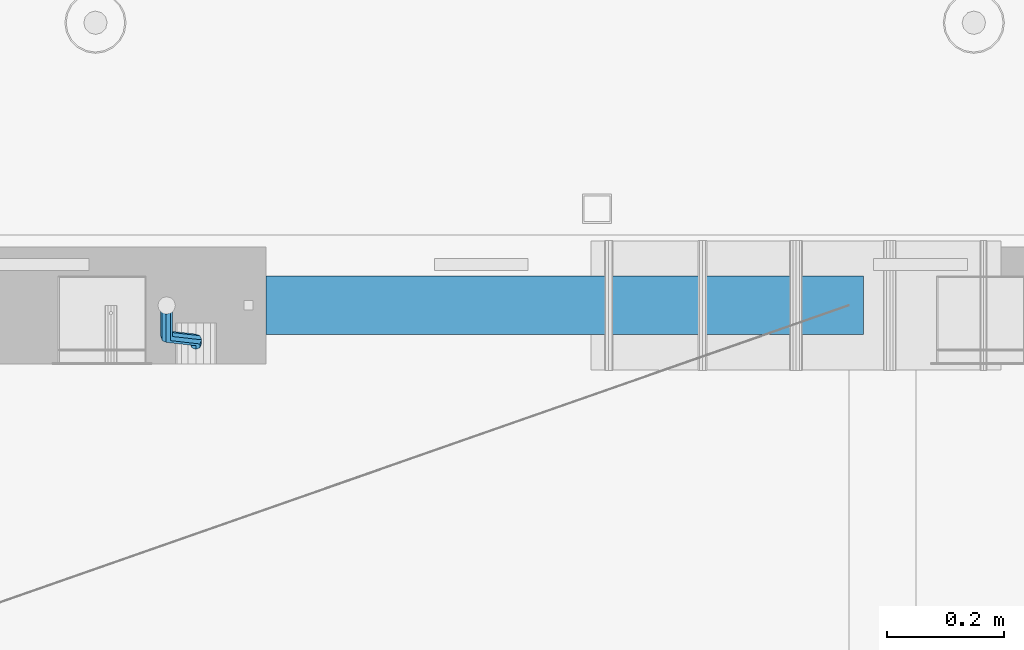
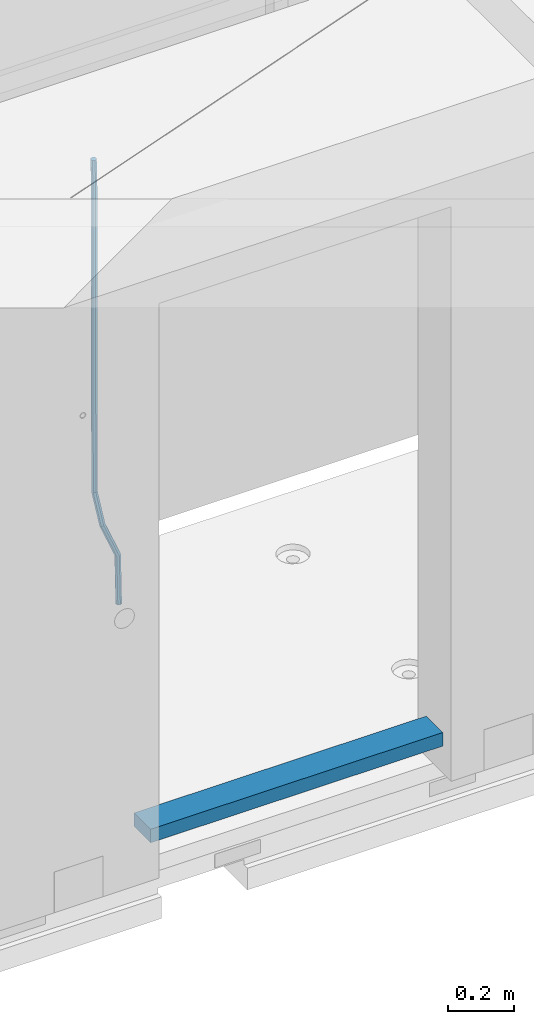
# One storey, part 111 of 352: 2 beams, 1 element without a shape of its own.
"""IFC2X3 building model written with IfcOpenShell, lengths in millimetres."""

from ifc_helpers import new_model, si_unit, frame, origin_with_axes, place, context, subcontext, project, spatial, faceted_brep, material, type_object, element, aggregate, save


model = new_model("IFC2X3")

# Units and contexts
model_context = context("Model", 3, precision=1e-05, world=origin_with_axes())
body_context = subcontext(model_context, "Body", "Model", "MODEL_VIEW")
ifc_project = project(units=[si_unit("LENGTHUNIT", "METRE", prefix="MILLI"), si_unit("AREAUNIT", "SQUARE_METRE"), si_unit("VOLUMEUNIT", "CUBIC_METRE"), si_unit("MASSUNIT", "GRAM", prefix="KILO"), si_unit("TIMEUNIT", "SECOND"), si_unit("PLANEANGLEUNIT", "RADIAN"), si_unit("SOLIDANGLEUNIT", "STERADIAN"), si_unit("THERMODYNAMICTEMPERATUREUNIT", "DEGREE_CELSIUS"), si_unit("LUMINOUSINTENSITYUNIT", "LUMEN")], contexts=[model_context])

# Site, building, storey
site_placement = place(None, origin_with_axes())
site = spatial("IfcSite", under=ifc_project, at=site_placement, CompositionType="ELEMENT")
building_placement = place(site_placement, origin_with_axes())
building = spatial("IfcBuilding", under=site, at=building_placement, CompositionType="ELEMENT")
storey_placement = place(building_placement, origin_with_axes())
storey = spatial("IfcBuildingStorey", under=building, at=storey_placement, Name="6", CompositionType="ELEMENT", Elevation=0.0)

# Assembly, beams
assembly_placement = place(storey_placement, origin_with_axes())
assembly = element("IfcElementAssembly", 1, at=assembly_placement, inside=storey, AssemblyPlace="NOTDEFINED", PredefinedType="REINFORCEMENT_UNIT")
ifc_material_1 = material()
beam_type_1 = type_object("IfcBeamType", Name="D20", PredefinedType="NOTDEFINED")
beam_1_placement = place(assembly_placement, frame((24379.9991455117, 15114.989587991, 97790.0076324386), z_axis=(-0.000205762999925498, 0.999642804629538, -0.0267249099901004), x_axis=(4.30000201928125e-08, 0.0267249099948059, 0.999642825806181)))
beam_1 = element("IfcBeam", 2, at=beam_1_placement, type_object=beam_type_1, material=ifc_material_1, Name="JM20", ObjectType="D20", context=body_context, shape_type="Brep", body=[
    faceted_brep([(0.0, -10.0, 0.0), (-4.19531716033816e-08, -7.07106781186667, -7.07106781187031), (60.4266690400545, -7.0710677960451, -7.07106780570757), (60.4266690441291, -9.99999998418934, 6.15546014159918e-09), (0.0, 0.0, -10.0), (60.426669036824, 1.58106558956206e-08, -9.99999999384454), (4.196772351861e-08, 7.07106781186303, -7.07106781186667), (60.4266690363438, 7.07106782768096, -7.07106780570757), (0.0, 10.0, 0.0), (60.4266690388904, 10.0000000158179, 6.15182216279209e-09), (4.196772351861e-08, 7.07106781185939, 7.07106781185939), (60.4266690429649, 7.07106782768096, 7.07106781802577), (0.0, 0.0, 10.0), (60.4266690461809, 1.58179318532348e-08, 10.0000000061555), (-4.19531716033816e-08, -7.07106781187031, 7.07106781185939), (60.4266690466611, -7.07106779605238, 7.07106781802213), (61.0378400410118, -7.07106779588503, -7.07106780564936), (60.991799419251, -9.99999998403655, 6.21366780251265e-09), (61.0569027789461, 1.5985278878361e-08, -9.99999999378269), (61.0378209396877, 7.07106782784831, -7.07106780564936), (60.9917724058905, 10.0000000159635, 6.21366780251265e-09), (60.9457317841297, 7.07106782781193, 7.0710678180767), (60.9266690461809, 1.59488990902901e-08, 10.0000000062028), (60.9457508854539, -7.07106779591413, 7.0710678180767), (61.6489592143771, -7.07106614513759, -7.06310863441468), (61.5568818710308, -9.9999984576425, 0.00735959856683621), (61.6870830769039, 1.71821739058942e-06, -9.99179257185824), (61.6489210170112, 7.07106947854481, -7.06310888312146), (61.556827851804, 10.0000015422847, 0.00735924683976918), (61.4647505084577, 7.07106922979438, 7.07782747982128), (61.4266266459163, 1.36643211590126e-06, 10.0065114172685), (61.464788705809, -7.07106639389531, 7.07782772852806), (174.621213165461, -7.07076098345351, -5.59176629582907), (174.529135822144, -9.99969329595478, 1.4787019371488), (174.659337027944, 0.000306879905110691, -8.52045023327446), (174.621174967935, 7.07137464022526, -5.59176654453404), (174.529081802684, 10.0003067039688, 1.47870158543083), (174.437004459352, 7.07137439147118, 8.5491698184087), (174.398880596913, 0.000306528108922066, 11.4778537558541), (174.437042656878, -7.07076123221123, 8.54917006711185), (175.716094779258, -7.07075802595864, -5.57750663810293), (175.029093421879, -9.99969194546793, 1.48521334821271), (177.145578432857, 0.000313595744955819, -8.48806960781258), (178.480172245545, 7.07138506415868, -5.54150724740612), (178.938089262141, 10.0003186135946, 1.53612417477052), (178.251087904748, 7.07138469408164, 8.59884416108434), (176.821604251149, 0.000313072378048673, 11.5094071307958), (175.487010438475, -7.07075839603567, 8.56284477038935), (176.73028205616, -7.48306481911277, -5.5575978012148), (175.49220343327, -10.1879642774365, 1.49430435328395), (179.448580299344, -0.935946733912715, -8.44286090764945), (182.054755918522, 5.61817699831226, -5.47133696928722), (183.022146581905, 8.33998958468874, 1.61629559169705), (181.784067959001, 5.63509012636496, 8.6681977461958), (179.065769715831, -0.912027958831459, 11.5534608526305), (176.459594096654, -7.4661516910528, 8.58193691426459), (294.295456565174, -55.2779062578775, -3.24975393820569), (293.057377942285, -57.9828057162013, 3.80214821629306), (297.013754808359, -48.7307881726811, -6.13501704463852), (299.619930427536, -42.1766644404597, -3.16349310627629), (300.587321090919, -39.454851854076, 3.92413945470616), (299.34924246803, -42.1597513124034, 10.9760416092031), (296.630944224846, -48.7068693975998, 13.8613047156396), (294.024768605668, -55.2609931298248, 10.8897807772755), (300.131186042752, -57.6503585272258, -3.13519660847487), (297.927214299008, -59.9625846556301, 3.89774473963917), (302.241773597852, -50.8561822796182, -6.0323892798333), (303.022623399127, -43.5599922135116, -3.09669710035814), (302.016324223136, -40.0357975159677, 3.95219126616212), (299.812352479406, -42.3480236443684, 10.9851326142743), (297.701764924292, -49.1421998919686, 13.8823252856328), (296.920915123032, -56.4383899580826, 10.9466331061594), (305.816309115588, -57.6497962814865, -0.41917616768842), (302.671371672826, -59.9621154692577, 6.16422661461002), (307.334869561208, -50.8556785840192, -3.59920488503303), (306.337500895927, -43.5596643796707, -1.51304184353285), (303.408448157163, -40.0356598380822, 4.61726694041863), (300.263510714387, -42.3479790258461, 11.2006697227207), (298.744950268767, -49.1420967233171, 14.3806984400617), (299.742318934063, -56.4381109276655, 12.2945353985633), (395.630203780689, -57.6409138916788, 42.488667805259), (392.485266337913, -59.9532330794427, 49.0720705875574), (397.148764226309, -50.8467961942151, 39.3086390879143), (396.151395561013, -43.5507819898594, 41.3948021294145), (393.22234282225, -40.0267774482672, 47.5251109133696), (390.077405379474, -42.3390966360348, 54.1085136956717), (388.558844933854, -49.1332143335057, 57.2885424130127), (389.556213599149, -56.4292285378579, 55.2023793715125), (396.844209099741, -57.640793829316, 43.0686487871244), (395.280625423067, -59.9529566247911, 50.4075302279853), (397.599922461304, -50.8467515756856, 39.5241761963625), (397.10507886979, -43.5506876727486, 41.8504164279075), (395.649550989881, -40.0265374029004, 48.6846895034632), (394.085967313207, -42.3387001983865, 56.0235709443259), (393.330253951674, -49.1327424520096, 59.5680435350878), (393.825097543173, -56.4288063549466, 57.241803303541), (398.189189358192, -57.6411602552034, 43.0337942646147), (398.377566371972, -59.9538003541529, 50.3272744790011), (398.099754636642, -50.8468877497689, 39.5112232837091), (398.161651854258, -43.550975525075, 41.8230358424771), (398.338622460418, -40.027270012466, 48.6150034976581), (398.526999474212, -42.3399101114192, 55.9084837120445), (398.616434195777, -49.13418261685, 59.4310546929501), (398.554536978161, -56.4300948415512, 57.1192421341821), (1517.19478070838, -57.9460216934422, 14.0352975759452), (1517.38315772217, -60.2586617923953, 21.3287777903333), (1517.10534598683, -51.1517491880113, 10.5127265950414), (1517.16724320444, -43.8558369633138, 12.8245391538094), (1517.34421381062, -40.3321314507048, 19.6165068089904), (1517.53259082441, -42.6447715496579, 26.9099870233767), (1517.62202554596, -49.4390440550887, 30.4325580042841), (1517.56012832835, -56.7349562797899, 28.1207454455143), (1518.02724982343, -57.946248491, 14.0137245355054), (1518.07759034891, -60.258850983344, 21.3107818997123), (1517.99524544395, -51.1519916318648, 10.4896652746502), (1518.00032494192, -43.8560639277712, 12.8029502375484), (1518.03951281632, -40.3323208776928, 19.5984884665704), (1518.08985334181, -42.6449233700369, 26.8955458307773), (1518.12185772131, -49.4391802291757, 30.4196050916289), (1518.11677822332, -56.735107933262, 28.1063201287325), (1518.85992470267, -57.9437654472204, 14.0245252313944), (1518.77219462092, -60.2567796673247, 21.3197916701429), (1518.8853648605, -51.149337287974, 10.5012110884654), (1518.83361259502, -43.8535790567003, 12.8137588817826), (1518.73498368141, -40.3302469774862, 19.6075094776534), (1518.64725359967, -42.6432611975906, 26.9027759164019), (1518.62181344185, -49.4376893568369, 30.4260900593326), (1518.67356570732, -56.7334475881107, 28.1135422660154), (1618.76572350181, -57.6458454809253, 15.3204117501973), (1618.67799342007, -59.9588597010261, 22.6156781889458), (1618.79116365965, -50.8514173216718, 11.7970976072666), (1618.73941139416, -43.5556590904016, 14.1096454005838), (1618.64078248056, -40.032327011184, 20.9033959964545), (1618.55305239883, -42.3453412312883, 28.198662435203), (1618.52761224099, -49.1397693905419, 31.7219765781338), (1618.57936450648, -56.4355276218121, 29.4094287848166)], [[[0, 1, 2, 3]], [[1, 4, 5, 2]], [[4, 6, 7, 5]], [[6, 8, 9, 7]], [[8, 10, 11, 9]], [[10, 12, 13, 11]], [[12, 14, 15, 13]], [[14, 0, 3, 15]], [[14, 12, 10, 8, 6, 4, 1, 0]], [[3, 2, 16, 17]], [[2, 5, 18, 16]], [[5, 7, 19, 18]], [[7, 9, 20, 19]], [[9, 11, 21, 20]], [[11, 13, 22, 21]], [[13, 15, 23, 22]], [[15, 3, 17, 23]], [[17, 16, 24, 25]], [[16, 18, 26, 24]], [[18, 19, 27, 26]], [[19, 20, 28, 27]], [[20, 21, 29, 28]], [[21, 22, 30, 29]], [[22, 23, 31, 30]], [[23, 17, 25, 31]], [[25, 24, 32, 33]], [[24, 26, 34, 32]], [[26, 27, 35, 34]], [[27, 28, 36, 35]], [[28, 29, 37, 36]], [[29, 30, 38, 37]], [[30, 31, 39, 38]], [[31, 25, 33, 39]], [[33, 32, 40, 41]], [[32, 34, 42, 40]], [[34, 35, 43, 42]], [[35, 36, 44, 43]], [[36, 37, 45, 44]], [[37, 38, 46, 45]], [[38, 39, 47, 46]], [[39, 33, 41, 47]], [[41, 40, 48, 49]], [[40, 42, 50, 48]], [[42, 43, 51, 50]], [[43, 44, 52, 51]], [[44, 45, 53, 52]], [[45, 46, 54, 53]], [[46, 47, 55, 54]], [[47, 41, 49, 55]], [[49, 48, 56, 57]], [[48, 50, 58, 56]], [[50, 51, 59, 58]], [[51, 52, 60, 59]], [[52, 53, 61, 60]], [[53, 54, 62, 61]], [[54, 55, 63, 62]], [[55, 49, 57, 63]], [[57, 56, 64, 65]], [[56, 58, 66, 64]], [[58, 59, 67, 66]], [[59, 60, 68, 67]], [[60, 61, 69, 68]], [[61, 62, 70, 69]], [[62, 63, 71, 70]], [[63, 57, 65, 71]], [[65, 64, 72, 73]], [[64, 66, 74, 72]], [[66, 67, 75, 74]], [[67, 68, 76, 75]], [[68, 69, 77, 76]], [[69, 70, 78, 77]], [[70, 71, 79, 78]], [[71, 65, 73, 79]], [[73, 72, 80, 81]], [[72, 74, 82, 80]], [[74, 75, 83, 82]], [[75, 76, 84, 83]], [[76, 77, 85, 84]], [[77, 78, 86, 85]], [[78, 79, 87, 86]], [[79, 73, 81, 87]], [[81, 80, 88, 89]], [[80, 82, 90, 88]], [[82, 83, 91, 90]], [[83, 84, 92, 91]], [[84, 85, 93, 92]], [[85, 86, 94, 93]], [[86, 87, 95, 94]], [[87, 81, 89, 95]], [[89, 88, 96, 97]], [[88, 90, 98, 96]], [[90, 91, 99, 98]], [[91, 92, 100, 99]], [[92, 93, 101, 100]], [[93, 94, 102, 101]], [[94, 95, 103, 102]], [[95, 89, 97, 103]], [[97, 96, 104, 105]], [[96, 98, 106, 104]], [[98, 99, 107, 106]], [[99, 100, 108, 107]], [[100, 101, 109, 108]], [[101, 102, 110, 109]], [[102, 103, 111, 110]], [[103, 97, 105, 111]], [[105, 104, 112, 113]], [[104, 106, 114, 112]], [[106, 107, 115, 114]], [[107, 108, 116, 115]], [[108, 109, 117, 116]], [[109, 110, 118, 117]], [[110, 111, 119, 118]], [[111, 105, 113, 119]], [[113, 112, 120, 121]], [[112, 114, 122, 120]], [[114, 115, 123, 122]], [[115, 116, 124, 123]], [[116, 117, 125, 124]], [[117, 118, 126, 125]], [[118, 119, 127, 126]], [[119, 113, 121, 127]], [[121, 120, 128, 129]], [[120, 122, 130, 128]], [[122, 123, 131, 130]], [[123, 124, 132, 131]], [[124, 125, 133, 132]], [[125, 126, 134, 133]], [[126, 127, 135, 134]], [[127, 121, 129, 135]], [[130, 131, 132, 133, 134, 135, 129, 128]]]),
])
ifc_material_2 = material(Name="TIMBER/T24")
beam_type_2 = type_object("IfcBeamType", PredefinedType="NOTDEFINED")
beam_2_placement = place(assembly_placement, frame((24500.0006866455, 15180.0, 96880.0), z_axis=(0.0, 0.0, 1.0), x_axis=(1.0, 0.0, 0.0)))
beam_2 = element("IfcBeam", 3, at=beam_2_placement, type_object=beam_type_2, material=ifc_material_2, context=body_context, shape_type="Brep", body=[
    faceted_brep([(0.0, 50.0, -25.0), (0.0, 50.0, 25.0), (1020.0, 50.0, 25.0), (1020.0, 50.0, -25.0), (0.0, -50.0, 25.0), (1020.0, -50.0, 25.0), (0.0, -50.0, -25.0), (1020.0, -50.0, -25.0)], [[[0, 1, 2, 3]], [[1, 4, 5, 2]], [[4, 6, 7, 5]], [[6, 0, 3, 7]], [[5, 7, 3, 2]], [[6, 4, 1, 0]]]),
])
aggregate(assembly, [beam_1, beam_2])

save(model, "model.ifc")
